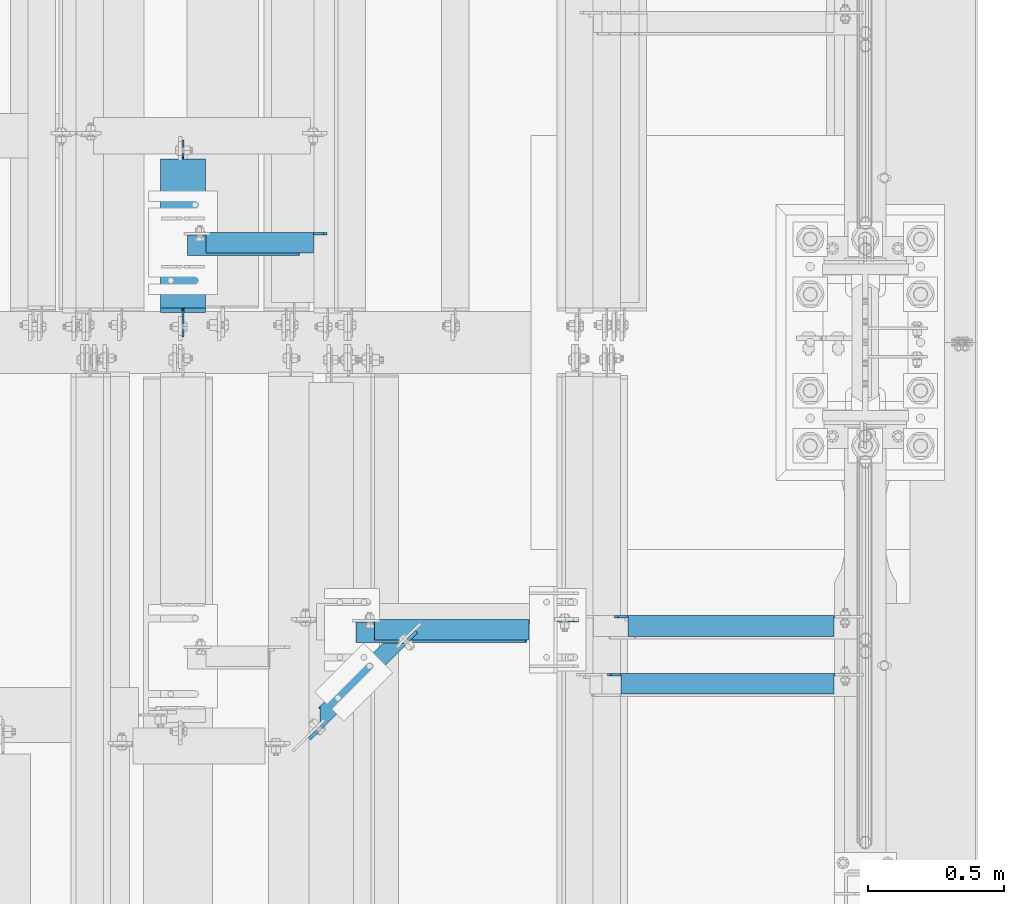
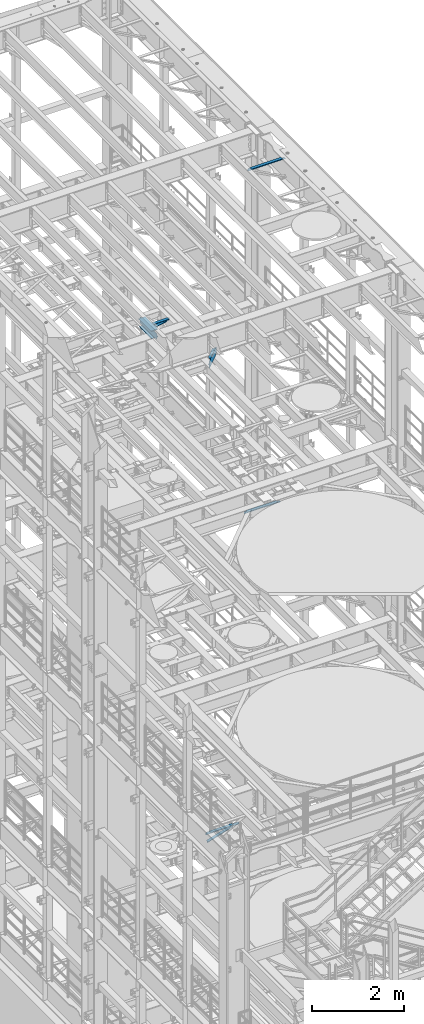
# One storey, part 1300 of 1876: 8 beams, 8 elements without a shape of their own.
"""IFC2X3 building model written with IfcOpenShell, lengths in millimetres."""

from ifc_helpers import new_model, si_unit, frame, origin_with_axes, place, context, subcontext, project, spatial, faceted_brep, material, type_object, element, aggregate, save


model = new_model("IFC2X3")

# Units and contexts
model_context = context("Model", 3, precision=1e-05, world=origin_with_axes())
body_context = subcontext(model_context, "Body", "Model", "MODEL_VIEW")
ifc_project = project(units=[si_unit("LENGTHUNIT", "METRE", prefix="MILLI"), si_unit("AREAUNIT", "SQUARE_METRE"), si_unit("VOLUMEUNIT", "CUBIC_METRE"), si_unit("MASSUNIT", "GRAM", prefix="KILO"), si_unit("TIMEUNIT", "SECOND"), si_unit("PLANEANGLEUNIT", "RADIAN"), si_unit("SOLIDANGLEUNIT", "STERADIAN"), si_unit("THERMODYNAMICTEMPERATUREUNIT", "DEGREE_CELSIUS"), si_unit("LUMINOUSINTENSITYUNIT", "LUMEN")], contexts=[model_context])

# Site, building, storey
site_placement = place(None, origin_with_axes())
site = spatial("IfcSite", under=ifc_project, at=site_placement, CompositionType="ELEMENT")
building_placement = place(site_placement, origin_with_axes())
building = spatial("IfcBuilding", under=site, at=building_placement, Name="Undefined", CompositionType="ELEMENT")
storey_placement = place(building_placement, origin_with_axes())
storey = spatial("IfcBuildingStorey", under=building, at=storey_placement, Name="Undefined", CompositionType="ELEMENT", Elevation=0.0)

# Assembly, beam
assembly_1_placement = place(storey_placement, origin_with_axes())
assembly_1 = element("IfcElementAssembly", 1, at=assembly_1_placement, inside=storey, Name="BEAM", AssemblyPlace="NOTDEFINED", PredefinedType="RIGID_FRAME")
ifc_material_1 = material(Name="STEEL/A992")
beam_type_1 = type_object("IfcBeamType", Name="W8X24", PredefinedType="NOTDEFINED")
beam_1_placement = place(assembly_1_placement, frame((5105.40030602581, 7620.00328419141, 17883.1875), z_axis=(0.0, 0.0, 1.0), x_axis=(0.0, 1.0, 0.0)))
beam_1 = element("IfcBeam", 2, at=beam_1_placement, type_object=beam_type_1, material=ifc_material_1, Name="BEAM", ObjectType="W8X24", context=body_context, shape_type="Brep", body=[
    faceted_brep([(19.8404658085947, -3.17500000000018, -80.9624999999978), (19.8404658085947, 3.17500000000018, -80.9624999999978), (99.2154659993294, 3.17500000000018, -80.9624999999978), (99.2154659993294, -3.17500000000018, -80.9624999999978), (104.075545517375, 3.17500000000018, -81.9292299225854), (104.075545517375, -3.17500000000018, -81.9292299225854), (108.195721985529, 3.17500000000018, -84.6822438230629), (108.195721985529, -3.17500000000018, -84.6822438230629), (110.948735886007, 3.17500000000018, -88.8024202912165), (110.948735886007, -3.17500000000018, -88.8024202912165), (111.915465808594, -82.5500000000002, -93.662499809263), (111.915465808594, 82.5500000000002, -93.662499809263), (111.915465808594, 82.5500000000002, -100.012500000001), (111.915465808594, -82.5500000000002, -100.012500000001), (111.283919080104, -82.5500000000002, -90.4874999999993), (111.283919080104, -3.17500000000018, -90.4874999999993), (111.283919080104, 3.17500000000018, -90.4874999999993), (111.283919080104, 82.5500000000002, -90.4874999999993), (676.271715808596, -82.5500000000002, 100.012500000001), (676.271715808596, 82.5500000000002, 100.012500000001), (127.790465808594, 82.5500000000002, 100.012500000001), (127.790465808594, -82.5500000000002, 100.012500000001), (676.903262537087, -82.5500000000002, 90.4874999999993), (676.271715808596, -82.5500000000002, 93.6624998092666), (127.790465808594, -82.5500000000002, 90.4874999999993), (676.271715808596, 82.5500000000002, 93.6624998092666), (676.903262537087, 82.5500000000002, 90.4874999999993), (127.790465808594, 82.5500000000002, 90.4874999999993), (676.903262537087, 3.17500000000018, 90.4874999999993), (127.790465808594, 3.17500000000018, 90.4874999999993), (115.090465999329, -3.17500000000018, 61.9125000000058), (115.090465999329, 3.17500000000018, 61.9125000000058), (19.8404658085947, 3.17500000000018, 61.9125000000058), (19.8404658085947, -3.17500000000018, 61.9125000000058), (119.950545517375, -3.17500000000018, 62.8792299225934), (119.950545517375, 3.17500000000018, 62.8792299225934), (124.070721985529, -3.17500000000018, 65.6322438230709), (124.070721985529, 3.17500000000018, 65.6322438230709), (126.823735886007, -3.17500000000018, 69.7524202912246), (126.823735886007, 3.17500000000018, 69.7524202912246), (127.790465808594, -3.17500000000018, 74.612499809271), (127.790465808594, 3.17500000000018, 74.612499809271), (127.790465808594, -3.17500000000018, 90.4874999999993), (676.903262537087, -3.17500000000018, 90.4874999999993), (677.238445731184, -3.17500000000018, 88.8024202912202), (677.238445731184, 3.17500000000018, 88.8024202912202), (679.991459631661, -3.17500000000018, 84.6822438230665), (679.991459631661, 3.17500000000018, 84.6822438230665), (684.111636099815, -3.17500000000018, 81.929229922589), (684.111636099815, 3.17500000000018, 81.929229922589), (688.971715617861, -3.17500000000018, 80.9625000000015), (688.971715617861, 3.17500000000018, 80.9625000000015), (746.121715808595, -3.17500000000018, 80.9625000000015), (746.121715808595, 3.17500000000018, 80.9625000000015), (746.121715808595, -3.17500000000018, -74.6124999999993), (746.121715808595, 3.17500000000018, -74.6124999999993), (666.746715617861, -3.17500000000018, -74.6124999999993), (666.746715617861, 3.17500000000018, -74.6124999999993), (661.886636099814, -3.17500000000018, -75.5792299225868), (661.886636099814, 3.17500000000018, -75.5792299225868), (657.766459631661, -3.17500000000018, -78.3322438230643), (657.766459631661, 3.17500000000018, -78.3322438230643), (655.013445731183, -3.17500000000018, -82.452420291218), (655.013445731183, 3.17500000000018, -82.452420291218), (654.046715808596, -3.17500000000018, -87.3124998092644), (654.046715808596, 3.17500000000018, -87.3124998092644), (654.046715808596, -3.17500000000018, -90.4874999999993), (654.046715808596, -82.5500000000002, -90.4874999999993), (654.046715808596, -82.5500000000002, -100.012500000001), (654.046715808596, 82.5500000000002, -100.012500000001), (654.046715808596, 82.5500000000002, -90.4874999999993), (654.046715808596, 3.17500000000018, -90.4874999999993)], [[[0, 1, 2, 3]], [[3, 2, 4, 5]], [[5, 4, 6, 7]], [[7, 6, 8, 9]], [[10, 11, 12, 13]], [[14, 15, 9, 8, 16, 17, 11, 10]], [[18, 19, 20, 21]], [[22, 23, 18, 21, 24]], [[18, 23, 25, 19]], [[19, 25, 26, 27, 20]], [[26, 28, 29, 27]], [[30, 31, 32, 33]], [[34, 35, 31, 30]], [[36, 37, 35, 34]], [[38, 39, 37, 36]], [[40, 41, 39, 38]], [[21, 20, 27, 29, 41, 40, 42, 24]], [[43, 22, 24, 42]], [[44, 45, 28, 26, 25, 23, 22, 43]], [[46, 47, 45, 44]], [[48, 49, 47, 46]], [[50, 51, 49, 48]], [[52, 53, 51, 50]], [[53, 52, 54, 55]], [[54, 56, 57, 55]], [[58, 59, 57, 56]], [[60, 61, 59, 58]], [[62, 63, 61, 60]], [[64, 65, 63, 62]], [[66, 67, 68, 69, 70, 71, 65, 64]], [[69, 68, 13, 12]], [[70, 69, 12, 11, 17]], [[71, 70, 17, 16]], [[6, 4, 2, 1, 32, 31, 35, 37, 39, 41, 29, 28, 45, 47, 49, 51, 53, 55, 57, 59, 61, 63, 65, 71, 16, 8]], [[33, 32, 1, 0]], [[66, 64, 62, 60, 58, 56, 54, 52, 50, 48, 46, 44, 43, 42, 40, 38, 36, 34, 30, 33, 0, 3, 5, 7, 9, 15]], [[67, 66, 15, 14]], [[68, 67, 14, 10, 13]]]),
])
aggregate(assembly_1, [beam_1])

assembly_2_placement = place(storey_placement, origin_with_axes())
assembly_2 = element("IfcElementAssembly", 3, at=assembly_2_placement, inside=storey, AssemblyPlace="NOTDEFINED", PredefinedType="RIGID_FRAME")
ifc_material_2 = material(Name="STEEL/A36")
beam_type_2 = type_object("IfcBeamType", Name="L3X3X3/8", PredefinedType="NOTDEFINED")
beam_2_placement = place(assembly_2_placement, frame((5113.17099876177, 7978.1823687033, 17834.775847094), z_axis=(0.0, -1.0, 0.0), x_axis=(0.978980391210151, 1.00999979382429e-07, 0.203954391043709)))
beam_2 = element("IfcBeam", 4, at=beam_2_placement, type_object=beam_type_2, material=ifc_material_2, ObjectType="L3X3X3/8", context=body_context, shape_type="Brep", body=[
    faceted_brep([(16.214587374594, 38.1000000000167, -38.0999999999985), (16.2145873619629, 38.0999999999549, 38.1000000000022), (435.881765256388, 38.0999999997439, 38.0999999998785), (435.881765269023, 38.0999999998094, -38.1000000001222), (16.214587361972, 28.5749999999571, 38.1000000000013), (435.881765256398, 28.5749999997461, 38.0999999998767), (16.2145873730242, 28.5750000000116, -28.5749999999998), (435.881765267453, 28.5749999998043, -28.5750000001235), (16.214587373086, -38.0999999999785, -28.5750000000135), (435.881765267512, -38.1000000001859, -28.5750000001381), (16.2145873746649, -38.0999999999731, -38.100000000014), (435.881765269092, -38.100000000175, -38.1000000001377)], [[[0, 1, 2, 3]], [[1, 4, 5, 2]], [[4, 6, 7, 5]], [[6, 8, 9, 7]], [[8, 10, 11, 9]], [[10, 0, 3, 11]], [[5, 7, 9, 11, 3, 2]], [[10, 8, 6, 4, 1, 0]]]),
])
aggregate(assembly_2, [beam_2])

assembly_3_placement = place(storey_placement, origin_with_axes())
assembly_3 = element("IfcElementAssembly", 5, at=assembly_3_placement, inside=storey, Name="ANGLE", AssemblyPlace="NOTDEFINED", PredefinedType="RIGID_FRAME")
beam_3_placement = place(assembly_3_placement, frame((5105.40026818549, 7987.70736790371, 17945.1), z_axis=(0.0, -1.0, 0.0), x_axis=(1.0, 0.0, 0.0)))
beam_3 = element("IfcBeam", 6, at=beam_3_placement, type_object=beam_type_2, material=ifc_material_2, Name="ANGLE", ObjectType="L3X3X3/8", context=body_context, shape_type="Brep", body=[
    faceted_brep([(84.1370686928021, 28.5750001907327, 38.100000000024), (84.1374011325761, 38.0999999999985, 38.0999999999776), (84.137408980816, 38.0999999999985, -38.1000000000231), (84.1370595487806, 28.5750001907327, -38.0999999999776), (84.1370606917826, 28.5750000000007, -28.5749999999771), (15.8750613722059, 28.5750001907327, -38.0999999999958), (15.8750625152097, 28.5750000000007, -28.5749999999953), (3.17506156294075, 15.8750003814675, -38.0999999999995), (3.17506270594458, 15.8750003814675, -28.5749999999989), (3.17506156294075, 3.17500152587672, -38.0999999999995), (3.17506270594458, 3.17500152587672, -28.5749999999989), (3.17506108428279, -38.0999999999985, -38.0999999999995), (3.17506206535836, -38.0999999999985, -28.5749999999989), (530.224737181856, 15.8750003814712, -28.5750000001462), (517.524737372591, 28.5750000000007, -28.5750000001426), (481.012735381319, 28.5750000000007, -28.5750000001317), (530.224734772813, -38.0999999999985, -28.5750000001453), (530.224737181856, 3.17500152588036, -28.5750000001462), (481.012730314029, 28.5750002008317, 38.0999999998685), (481.012730314029, 38.0999999999985, 38.0999999998685), (481.012736105216, 38.0999999999985, -38.1000000001322), (481.012736105216, 28.5750001907363, -38.1000000001322), (517.524738096489, 28.5750001907363, -38.1000000001422), (530.224737905754, 15.8750003814712, -38.1000000001459), (530.224737905754, 3.17500152588036, -38.1000000001459), (530.224735753888, -38.0999999999985, -38.1000000001459)], [[[0, 1, 2, 3, 4]], [[4, 3, 5, 6]], [[6, 5, 7, 8]], [[8, 7, 9, 10]], [[9, 11, 12, 10]], [[13, 14, 15, 4, 6, 8, 10, 12, 16, 17]], [[0, 4, 15, 18]], [[1, 0, 18, 19]], [[2, 1, 19, 20]], [[18, 15, 21, 20, 19]], [[14, 22, 21, 15]], [[13, 23, 22, 14]], [[17, 24, 23, 13]], [[11, 9, 7, 5, 3, 2, 20, 21, 22, 23, 24, 25]], [[12, 11, 25, 16]], [[24, 17, 16, 25]]]),
])
aggregate(assembly_3, [beam_3])

assembly_4_placement = place(storey_placement, origin_with_axes())
assembly_4 = element("IfcElementAssembly", 7, at=assembly_4_placement, inside=storey, AssemblyPlace="NOTDEFINED", PredefinedType="RIGID_FRAME")
beam_4_placement = place(assembly_4_placement, frame((5727.69996452367, 6551.85545286742, 4867.27500000001), z_axis=(0.0, -1.0, 0.0), x_axis=(0.953964189281616, -1.20000003690115e-08, 0.299920532088533)))
beam_4 = element("IfcBeam", 8, at=beam_4_placement, type_object=beam_type_2, material=ifc_material_2, ObjectType="L3X3X3/8", context=body_context, shape_type="Brep", body=[
    faceted_brep([(28.6194938924073, 38.100000000014, -38.1000000000067), (28.6194938618237, 38.0999999999767, 38.0999999999931), (683.360898815113, 38.0999999999208, 38.0999999999112), (683.360898845696, 38.0999999999581, -38.1000000000895), (28.6194938618237, 28.5749999999771, 38.099999999994), (683.360898815113, 28.5749999999211, 38.0999999999112), (28.6194938885847, 28.5750000000098, -28.5750000000062), (683.360898841872, 28.5749999999539, -28.5750000000889), (28.6194938885847, -38.0999999999854, -28.5750000000035), (683.360898841874, -38.1000000000422, -28.5750000000862), (28.6194938924091, -38.0999999999808, -38.1000000000031), (683.360898845695, -38.1000000000377, -38.1000000000859)], [[[0, 1, 2, 3]], [[1, 4, 5, 2]], [[4, 6, 7, 5]], [[6, 8, 9, 7]], [[8, 10, 11, 9]], [[10, 0, 3, 11]], [[5, 7, 9, 11, 3, 2]], [[10, 8, 6, 4, 1, 0]]]),
])
aggregate(assembly_4, [beam_4])

assembly_5_placement = place(storey_placement, origin_with_axes())
assembly_5 = element("IfcElementAssembly", 9, at=assembly_5_placement, inside=storey, Name="ANGLE", AssemblyPlace="NOTDEFINED", PredefinedType="RIGID_FRAME")
beam_5_placement = place(assembly_5_placement, frame((5727.70004205155, 6561.38045286749, 5092.7), z_axis=(0.0, -1.0, 0.0), x_axis=(1.0, 0.0, 0.0)))
beam_5 = element("IfcBeam", 10, at=beam_5_placement, type_object=beam_type_2, material=ifc_material_2, Name="ANGLE", ObjectType="L3X3X3/8", context=body_context, shape_type="Brep", body=[
    faceted_brep([(84.137014014791, 28.5749999999998, 38.1000000000258), (84.1373129237786, 38.0999999999985, 38.0999999999835), (84.1373049986182, 38.0999999999985, -38.1000000000167), (84.1369574531245, 26.9870094055223, -38.099999999974), (84.1369575769495, 26.9870083863452, -28.5749999999744), (84.1370606917826, 28.5750000000007, -28.5749999999771), (22.2249551643299, 26.9870094055232, -38.0999999999931), (22.2249552881549, 26.9870083863452, -28.5749999999935), (3.17495592726937, 7.93701016846171, -38.0999999999995), (3.17495605109434, 7.93700914928468, -28.5749999999989), (3.17495592726937, 1.58700978699198, -38.0999999999995), (3.17495605109434, 1.58700876781495, -28.5749999999989), (3.17492999904698, -38.0999999999985, -38.1000000000013), (3.17493098964678, -38.0999999999985, -28.5750000000012), (835.024961298736, 7.93700065612848, -28.5749999997352), (815.974962061676, 26.986999893189, -28.5749999997415), (652.461957758697, 26.986999893189, -28.5749999997934), (652.461957758697, 28.5749999999998, -28.5749999997934), (835.024957576975, -38.1000000000004, -28.5749999997352), (835.024961298736, 1.58700027465875, -28.5749999997352), (652.461959158867, 28.5749999999998, 38.1000000002068), (652.461959158867, 38.1000000000004, 38.1000000002068), (652.461957558674, 38.1000000000004, -38.099999999793), (652.461957558674, 26.986999893189, -38.099999999793), (815.974961861652, 26.986999893189, -38.0999999997421), (835.024961098713, 7.93700065612848, -38.0999999997357), (835.024961098713, 1.58700027465875, -38.0999999997357), (835.02495745315, -38.1000000000004, -38.0999999997357)], [[[0, 1, 2, 3, 4, 5]], [[4, 3, 6, 7]], [[7, 6, 8, 9]], [[9, 8, 10, 11]], [[10, 12, 13, 11]], [[14, 15, 16, 17, 5, 4, 7, 9, 11, 13, 18, 19]], [[0, 5, 17, 20]], [[1, 0, 20, 21]], [[2, 1, 21, 22]], [[20, 17, 16, 23, 22, 21]], [[15, 24, 23, 16]], [[14, 25, 24, 15]], [[19, 26, 25, 14]], [[12, 10, 8, 6, 3, 2, 22, 23, 24, 25, 26, 27]], [[13, 12, 27, 18]], [[26, 19, 18, 27]]]),
])
aggregate(assembly_5, [beam_5])

assembly_6_placement = place(storey_placement, origin_with_axes())
assembly_6 = element("IfcElementAssembly", 11, at=assembly_6_placement, inside=storey, Name="ANGLE", AssemblyPlace="NOTDEFINED", PredefinedType="RIGID_FRAME")
beam_6_placement = place(assembly_6_placement, frame((6667.50000000002, 6362.7, 22517.1000001129), z_axis=(0.0, -1.0, 0.0), x_axis=(1.0, 0.0, 0.0)))
beam_6 = element("IfcBeam", 12, at=beam_6_placement, type_object=beam_type_2, material=ifc_material_2, Name="ANGLE", ObjectType="L3X3X3/8", context=body_context, shape_type="Brep", body=[
    faceted_brep([(836.613000301995, 28.5750000000007, -28.5749999999998), (836.613001168791, 28.5750000000007, 38.0999999999999), (52.3870335430847, 28.5750001907327, 38.0999999999858), (52.3869956588824, 28.5749999999955, -28.5750000000007), (836.613001168791, 38.0999999999985, 38.0999999999999), (52.387033543122, 38.0999999999985, 38.0999999999858), (15.8749936676099, 28.5749999999989, -28.5750000000007), (15.8749999382144, 28.5750001907327, -38.0999999999999), (3.17500012894925, 15.8750003814675, -38.0999999999999), (3.17500032897624, 15.8750003814675, -28.5749999999998), (52.3870393343063, 28.5750001907327, -38.1000000000149), (52.3869953826566, 38.0999999999954, -38.0999999999985), (836.613000178167, 38.0999999999985, -38.0999999999999), (836.613000301995, 12.6999991241828, -28.5749999999998), (836.613000178167, 12.6999991241828, -38.0999999999999), (913.60625591723, 12.6999991241828, -28.5749999999998), (913.606255793401, 12.6999991241828, -38.0999999999999), (945.35625591723, -19.0500008758172, -28.5749999999998), (945.356255793401, -19.0500008758172, -38.0999999999999), (945.356249999983, -38.0999999999985, -28.5749999999998), (945.356249999983, -38.0999999999985, -38.0999999999999), (3.17499999075153, -38.0999999999985, -28.5749999999998), (3.17499999075153, -38.0999999999985, -38.0999999999999), (3.17500012894925, 3.17500152587672, -38.0999999999999), (3.17500032897624, 3.17500152587672, -28.5749999999998)], [[[0, 1, 2, 3]], [[1, 4, 5, 2]], [[6, 7, 8, 9]], [[3, 10, 7, 6]], [[2, 5, 11, 10, 3]], [[4, 12, 11, 5]], [[1, 0, 13, 14, 12, 4]], [[15, 16, 14, 13]], [[16, 15, 17, 18]], [[18, 17, 19, 20]], [[20, 19, 21, 22]], [[8, 7, 10, 11, 12, 14, 16, 18, 20, 22, 23]], [[9, 8, 23, 24]], [[19, 17, 15, 13, 0, 3, 6, 9, 24, 21]], [[23, 22, 21, 24]]]),
])
aggregate(assembly_6, [beam_6])

assembly_7_placement = place(storey_placement, origin_with_axes())
assembly_7 = element("IfcElementAssembly", 13, at=assembly_7_placement, inside=storey, Name="ANGLE", AssemblyPlace="NOTDEFINED", PredefinedType="RIGID_FRAME")
beam_7_placement = place(assembly_7_placement, frame((6692.89999993464, 6575.425, 13271.5), z_axis=(0.0, -1.0, 0.0), x_axis=(1.0, 0.0, 0.0)))
beam_7 = element("IfcBeam", 14, at=beam_7_placement, type_object=beam_type_2, material=ifc_material_2, Name="ANGLE", ObjectType="L3X3X3/8", context=body_context, shape_type="Brep", body=[
    faceted_brep([(811.213000367367, 28.5750000000007, -28.5749999999998), (811.213001234163, 28.5750000000007, 38.0999999999999), (52.3870335430847, 28.5750001907327, 38.0999999999858), (52.3869956588824, 28.5749999999955, -28.5750000000007), (811.213001234163, 38.1000000000004, 38.0999999999999), (52.387033543122, 38.0999999999985, 38.0999999999858), (15.8749959074521, 26.988000297546, -28.5749999999998), (15.8749956502761, 26.988000297546, -38.0999999999999), (3.17499584101097, 14.2880004882809, -38.0999999999999), (3.17499609818697, 14.2880004882809, -28.5749999999998), (52.3869978987241, 26.988000297546, -28.5749999999998), (52.3869976415481, 26.988000297546, -38.0999999999999), (52.3869953826566, 38.0999999999954, -38.0999999999985), (811.213000243539, 38.1000000000004, -38.0999999999999), (811.213000367367, 12.6999992370602, -28.5749999999998), (811.213000243539, 12.6999992370602, -38.0999999999999), (888.206248353207, 12.6999992370602, -28.5749999999998), (888.206248229379, 12.6999992370602, -38.0999999999999), (919.956248353207, -19.0500007629398, -28.5749999999998), (919.956248229379, -19.0500007629398, -38.0999999999999), (919.956250065358, -38.1000000000004, -28.5749999999998), (919.956250065358, -38.1000000000004, -38.0999999999999), (3.17499999075153, -38.0999999999985, -28.5749999999998), (3.17499999075153, -38.0999999999985, -38.0999999999999), (3.17499584101097, 1.58799972534143, -38.0999999999999), (3.17499609818697, 1.58799972534143, -28.5749999999998)], [[[0, 1, 2, 3]], [[1, 4, 5, 2]], [[6, 7, 8, 9]], [[10, 11, 7, 6]], [[2, 5, 12, 11, 10, 3]], [[4, 13, 12, 5]], [[1, 0, 14, 15, 13, 4]], [[16, 17, 15, 14]], [[17, 16, 18, 19]], [[19, 18, 20, 21]], [[21, 20, 22, 23]], [[8, 7, 11, 12, 13, 15, 17, 19, 21, 23, 24]], [[9, 8, 24, 25]], [[20, 18, 16, 14, 0, 3, 10, 6, 9, 25, 22]], [[24, 23, 22, 25]]]),
])
aggregate(assembly_7, [beam_7])

assembly_8_placement = place(storey_placement, origin_with_axes())
assembly_8 = element("IfcElementAssembly", 15, at=assembly_8_placement, inside=storey, Name="BEAM", AssemblyPlace="NOTDEFINED", PredefinedType="RIGID_FRAME")
beam_type_3 = type_object("IfcBeamType", Name="C8X18.75", PredefinedType="NOTDEFINED")
beam_8_placement = place(assembly_8_placement, frame((5581.01179284749, 6205.54901045283, 17881.6), z_axis=(0.0, 0.0, -1.0), x_axis=(0.707106781186548, 0.707106781186547, 0.0)))
beam_8 = element("IfcBeam", 16, at=beam_8_placement, type_object=beam_type_3, material=ifc_material_2, Name="BEAM", ObjectType="C8X18.75", context=body_context, shape_type="Brep", body=[
    faceted_brep([(64.5894877559858, -31.750000000006, 101.599999999999), (64.5894877559858, -31.750000000006, 97.3645499999984), (400.69088966504, -31.7500000000069, 97.3645499999984), (400.69088966504, -31.7500000000069, 101.599999999999), (464.190889665051, 31.7500000000049, 101.599999999999), (441.969702334534, 9.52881266948623, 90.4874998092637), (464.190889665051, 31.750000000004, 90.4874998092637), (73.0637137553058, -31.7500000000056, -97.3645499999984), (73.0637137553058, -31.7500000000056, -101.599999999999), (400.690889664498, -31.750000000006, -101.599999999999), (400.690889664498, -31.750000000006, -97.3645499999984), (21.8175000645751, 19.0500000000028, -88.9012699999985), (31.7849010857917, 9.52881266950851, -90.48749980926), (441.969702333992, 9.52881266948714, -90.4874998092637), (451.937103355232, 19.0500000000033, -88.9012699999985), (4.30320178289367, 19.0500000000023, -77.7874999999949), (-8.3967982171107, 31.7500000000049, -77.7874999999949), (-1.52360784847588, 31.7500000000049, -78.7542299225825), (11.1763921515285, 19.0500000000023, -78.7542299225825), (4.30320159216171, 31.7500000000049, -81.50724382306), (17.0032015921624, 19.0500000000033, -81.50724382306), (8.19655118761875, 31.7500000000053, -85.6274202912136), (20.8965511876213, 19.0500000000028, -85.6274202912136), (9.56371375529488, 31.7500000000044, -90.48749980926), (9.56371375529488, 31.7500000000044, -101.599999999999), (464.190889664511, 31.750000000004, -101.599999999999), (464.190889664509, 31.7500000000049, -90.4874998092637), (465.558052232185, 31.7500000000049, -85.6274202912173), (452.858052232184, 19.0500000000033, -85.6274202912173), (469.451401827646, 31.7500000000058, -81.5072438230636), (456.751401827643, 19.0500000000033, -81.5072438230636), (475.278211268282, 31.7500000000049, -78.7542299225861), (462.578211268279, 19.0500000000033, -78.7542299225861), (482.151401636916, 31.7500000000049, -77.7874999999985), (469.451401636912, 19.0500000000023, -77.7874999999985), (518.304727030651, 31.7500000000049, -77.7874999999985), (518.304727030651, 19.0500000000023, -77.7874999999985), (518.304727030651, 31.7500000000049, 77.7874999999985), (518.304727030651, 19.0500000000023, 77.7874999999985), (482.151401637455, 31.7500000000058, 77.7874999999985), (469.451401637452, 19.0500000000033, 77.7874999999985), (475.27821126882, 31.7500000000049, 78.7542299225861), (462.578211268819, 19.0500000000033, 78.7542299225861), (469.451401828186, 31.7500000000058, 81.5072438230636), (456.751401828184, 19.0500000000033, 81.5072438230636), (465.558052232727, 31.7500000000049, 85.6274202912173), (452.858052232725, 19.0500000000033, 85.6274202912173), (451.937103355773, 19.0500000000033, 88.9012699999985), (64.5894877559858, 19.0500000000033, 88.9012699999985), (64.5894877559858, 19.0499999053353, 101.599999999999), (-39.1894877598879, 19.0499999053349, 101.599999999999), (-39.1894877598879, 19.0500000000023, 88.9012699999985), (-39.1894877598879, 19.0500000000023, -77.7874999999949), (-39.1894877598879, 31.7500000000049, -77.7874999999949), (-39.1894877598879, 31.7500000000049, 101.599999999999)], [[[0, 1, 2, 3]], [[4, 3, 2, 5, 6]], [[7, 8, 9, 10]], [[11, 12, 7, 10, 13, 14]], [[15, 16, 17, 18]], [[18, 17, 19, 20]], [[20, 19, 21, 22]], [[11, 22, 21, 23, 12]], [[7, 12, 23, 24, 8]], [[8, 24, 25, 9]], [[26, 13, 10, 9, 25]], [[27, 28, 14, 13, 26]], [[29, 30, 28, 27]], [[31, 32, 30, 29]], [[33, 34, 32, 31]], [[34, 33, 35, 36]], [[35, 37, 38, 36]], [[39, 40, 38, 37]], [[41, 42, 40, 39]], [[43, 44, 42, 41]], [[45, 46, 44, 43]], [[6, 5, 47, 46, 45]], [[2, 1, 48, 47, 5]], [[0, 49, 48, 1]], [[48, 49, 50, 51]], [[15, 18, 20, 22, 11, 14, 28, 30, 32, 34, 36, 38, 40, 42, 44, 46, 47, 48, 51, 52]], [[16, 15, 52, 53]], [[4, 6, 45, 43, 41, 39, 37, 35, 33, 31, 29, 27, 26, 25, 24, 23, 21, 19, 17, 16, 53, 54]], [[49, 0, 3, 4, 54, 50]], [[53, 52, 51, 50, 54]]]),
])
aggregate(assembly_8, [beam_8])

save(model, "model.ifc")
